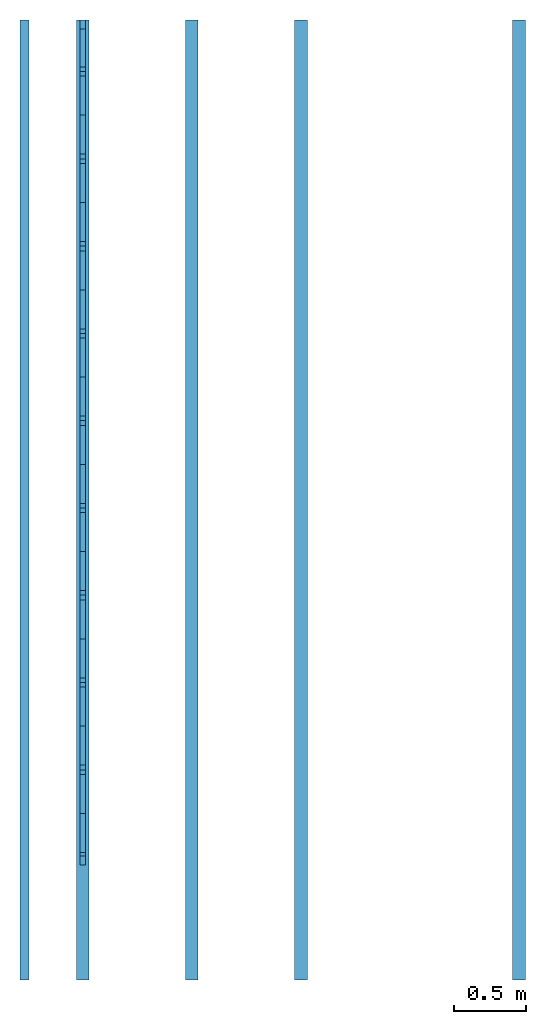
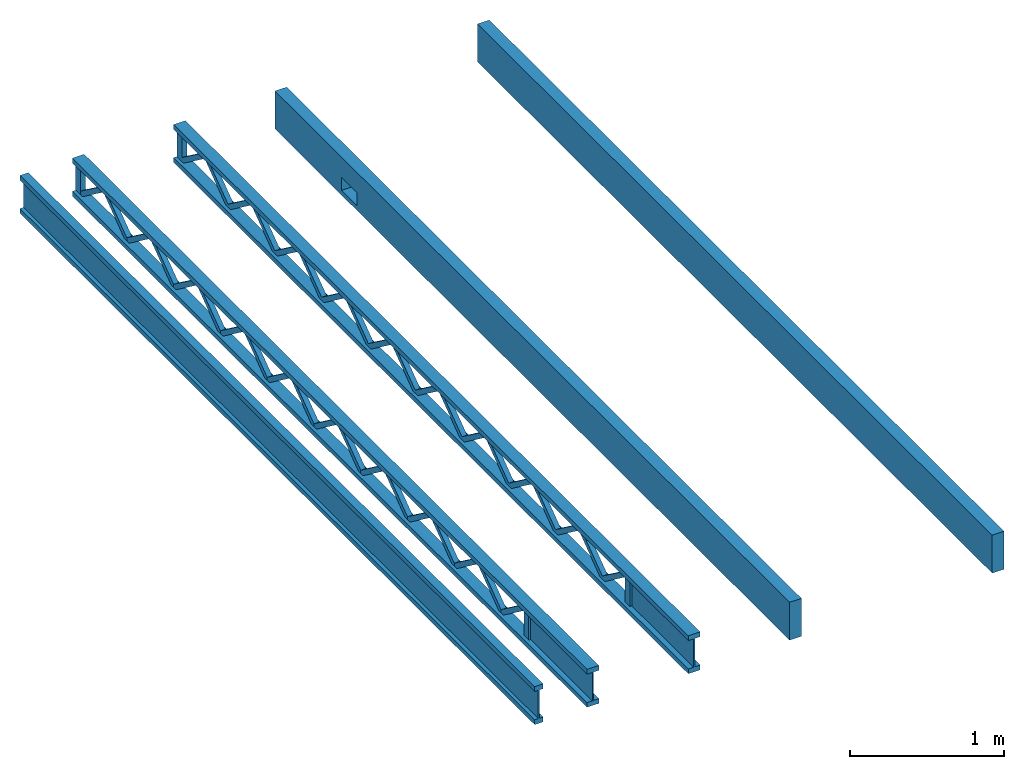
# One storey: 26 members.
"""IFC2X3 building model written with IfcOpenShell, lengths in metres."""

from ifc_helpers import new_model, si_unit, direction, frame, origin_with_axes, place, context, subcontext, project, spatial, faceted_brep, material, element, save


model = new_model("IFC2X3")

# Units and contexts
model_context = context("Model", 3, precision=1e-06, world=origin_with_axes(), true_north=direction((0.0, 1.0)))
body_context = subcontext(model_context, "Body", "Model", "MODEL_VIEW")
ifc_project = project(units=[si_unit("LENGTHUNIT", "METRE"), si_unit("AREAUNIT", "SQUARE_METRE"), si_unit("VOLUMEUNIT", "CUBIC_METRE"), si_unit("PLANEANGLEUNIT", "RADIAN"), si_unit("MASSUNIT", "GRAM", prefix="KILO")], contexts=[model_context])

# Site, building, storey
site_placement = place(None, origin_with_axes())
site = spatial("IfcSite", under=ifc_project, at=site_placement, CompositionType="ELEMENT")
building_placement = place(site_placement, origin_with_axes())
building = spatial("IfcBuilding", under=site, at=building_placement, Name="Building 1", CompositionType="ELEMENT")
storey_placement = place(building_placement, origin_with_axes())
storey = spatial("IfcBuildingStorey", under=building, at=storey_placement, Name="Storey 1", CompositionType="ELEMENT", Elevation=0.0)

# Members
ifc_material_1 = material(Name="Glass")
member_1_placement = place(storey_placement, frame((58.88355, 9.0424, -39.8871125), z_axis=(0.0, 0.0, 1.0), x_axis=(0.0, -1.0, 0.0)))
element("IfcMember", 1, at=member_1_placement, inside=storey, material=ifc_material_1, Name="Rough Volume Truss", context=body_context, shape_type="Brep", body=[
    faceted_brep([(0.0, -0.04445, -0.1508125), (0.0, 0.04445, -0.1508125), (6.7056, 0.04445, -0.1508125), (6.7056, -0.04445, -0.1508125), (0.0, 0.04445, 0.1508125), (6.7056, 0.04445, 0.1508125), (0.0, -0.04445, 0.1508125), (6.7056, -0.04445, 0.1508125)], [[[0, 1, 2, 3]], [[2, 1, 4, 5]], [[1, 0, 6, 4]], [[3, 2, 5, 7]], [[0, 3, 7, 6]], [[5, 4, 6, 7]]]),
])
ifc_material_2 = material(Name="fir")
member_2_placement = place(storey_placement, frame((55.42915, 9.0424, -39.8871125), z_axis=(0.0, 0.0, 1.0), x_axis=(0.0, -1.0, 0.0)))
element("IfcMember", 2, at=member_2_placement, inside=storey, material=ifc_material_2, Name="I Joist", context=body_context, shape_type="Brep", body=[
    faceted_brep([(0.0, 0.0047625, -0.1127125), (0.0, 0.0047625, 0.1127125), (6.7056, 0.0047625, 0.1127125), (6.7056, 0.0047625, -0.1127125), (0.0, 0.03175, 0.1127125), (6.7056, 0.03175, 0.1127125), (0.0, 0.03175, 0.1508125), (6.7056, 0.03175, 0.1508125), (0.0, -0.03175, 0.1508125), (6.7056, -0.03175, 0.1508125), (0.0, -0.03175, 0.1127125), (6.7056, -0.03175, 0.1127125), (0.0, -0.0047625, 0.1127125), (6.7056, -0.0047625, 0.1127125), (0.0, -0.0047625, -0.1127125), (6.7056, -0.0047625, -0.1127125), (0.0, -0.03175, -0.1127125), (6.7056, -0.03175, -0.1127125), (0.0, -0.03175, -0.1508125), (6.7056, -0.03175, -0.1508125), (0.0, 0.03175, -0.1508125), (6.7056, 0.03175, -0.1508125), (0.0, 0.03175, -0.1127125), (6.7056, 0.03175, -0.1127125)], [[[0, 1, 2, 3]], [[1, 4, 5, 2]], [[5, 4, 6, 7]], [[7, 6, 8, 9]], [[10, 11, 9, 8]], [[10, 12, 13, 11]], [[12, 14, 15, 13]], [[14, 16, 17, 15]], [[17, 16, 18, 19]], [[19, 18, 20, 21]], [[22, 23, 21, 20]], [[22, 0, 3, 23]], [[0, 22, 20, 18, 16, 14, 12, 10, 8, 6, 4, 1]], [[23, 3, 2, 5, 7, 9, 11, 13, 15, 17, 19, 21]]]),
])
member_3_placement = place(storey_placement, frame((55.83555, 5.6342122, -39.7741643), z_axis=(0.0, -0.595333, -0.8034791), x_axis=(0.0, 0.8034791, -0.595333)))
element("IfcMember", 3, at=member_3_placement, inside=storey, material=ifc_material_2, context=body_context, shape_type="Brep", body=[
    faceted_brep([(0.3791034, -0.01905, -3.98e-05), (0.3791034, 0.01905, -3.98e-05), (0.3533391, 0.01905, 0.01905), (0.3533391, -0.01905, 0.01905), (0.0138976, -0.01905, 0.01905), (0.0, -0.01905, 0.0002934), (0.0261064, -0.01905, -0.01905), (0.3650179, -0.01905, -0.01905), (0.3650179, 0.01905, -0.01905), (0.0261064, 0.01905, -0.01905), (0.0, 0.01905, 0.0002934), (0.0138976, 0.01905, 0.01905)], [[[0, 1, 2, 3]], [[0, 3, 4, 5, 6, 7]], [[1, 0, 7, 8]], [[8, 7, 6, 9]], [[2, 1, 8, 9, 10, 11]], [[5, 10, 9, 6]], [[10, 5, 4, 11]], [[3, 2, 11, 4]]]),
])
member_4_placement = place(storey_placement, frame((55.83555, 5.6338628, -39.7741643), z_axis=(0.0, 0.595333, -0.8034791), x_axis=(0.0, -0.8034791, -0.595333)))
element("IfcMember", 4, at=member_4_placement, inside=storey, material=ifc_material_2, context=body_context, shape_type="Brep", body=[
    faceted_brep([(0.3791034, -0.01905, -3.98e-05), (0.3791034, 0.01905, -3.98e-05), (0.3533391, 0.01905, 0.01905), (0.3533391, -0.01905, 0.01905), (0.3650179, 0.01905, -0.01905), (0.0261064, 0.01905, -0.01905), (0.0, 0.01905, 0.0002934), (0.0138976, 0.01905, 0.01905), (0.3650179, -0.01905, -0.01905), (0.0261064, -0.01905, -0.01905), (0.0138976, -0.01905, 0.01905), (0.0, -0.01905, 0.0002934)], [[[0, 1, 2, 3]], [[2, 1, 4, 5, 6, 7]], [[1, 0, 8, 4]], [[4, 8, 9, 5]], [[0, 3, 10, 11, 9, 8]], [[11, 6, 5, 9]], [[6, 11, 10, 7]], [[3, 2, 7, 10]]]),
])
member_5_placement = place(storey_placement, frame((55.83555, 8.6822122, -39.7741643), z_axis=(0.0, -0.595333, -0.8034791), x_axis=(0.0, 0.8034791, -0.595333)))
element("IfcMember", 5, at=member_5_placement, inside=storey, material=ifc_material_2, context=body_context, shape_type="Brep", body=[
    faceted_brep([(0.3791034, -0.01905, -3.98e-05), (0.3791034, 0.01905, -3.98e-05), (0.3533391, 0.01905, 0.01905), (0.3533391, -0.01905, 0.01905), (0.0138976, -0.01905, 0.01905), (0.0, -0.01905, 0.0002934), (0.0261064, -0.01905, -0.01905), (0.3650179, -0.01905, -0.01905), (0.3650179, 0.01905, -0.01905), (0.0261064, 0.01905, -0.01905), (0.0, 0.01905, 0.0002934), (0.0138976, 0.01905, 0.01905)], [[[0, 1, 2, 3]], [[0, 3, 4, 5, 6, 7]], [[1, 0, 7, 8]], [[8, 7, 6, 9]], [[2, 1, 8, 9, 10, 11]], [[5, 10, 9, 6]], [[10, 5, 4, 11]], [[3, 2, 11, 4]]]),
])
member_6_placement = place(storey_placement, frame((55.83555, 9.01065, -39.7744), z_axis=(0.0, -1.0, 0.0), x_axis=(0.0, 0.0, -1.0)))
element("IfcMember", 6, at=member_6_placement, inside=storey, material=ifc_material_2, context=body_context, shape_type="Brep", body=[
    faceted_brep([(0.225425, 0.01905, -0.03175), (0.225425, 0.01905, 0.03175), (0.225425, -0.01905, 0.03175), (0.225425, -0.01905, -0.03175), (0.0, 0.01905, 0.03175), (0.0, 0.01905, -0.03175), (0.0, -0.01905, -0.03175), (0.0, -0.01905, 0.03175)], [[[0, 1, 2, 3]], [[4, 5, 6, 7]], [[3, 6, 5, 0]], [[2, 7, 6, 3]], [[1, 4, 7, 2]], [[0, 5, 4, 1]]]),
])
member_7_placement = place(storey_placement, frame((55.83555, 3.8050628, -39.7741643), z_axis=(0.0, 0.595333, -0.8034791), x_axis=(0.0, -0.8034791, -0.595333)))
element("IfcMember", 7, at=member_7_placement, inside=storey, material=ifc_material_2, context=body_context, shape_type="Brep", body=[
    faceted_brep([(0.3791034, -0.01905, -3.98e-05), (0.3791034, 0.01905, -3.98e-05), (0.3533391, 0.01905, 0.01905), (0.3533391, -0.01905, 0.01905), (0.3650179, 0.01905, -0.01905), (0.0261064, 0.01905, -0.01905), (0.0, 0.01905, 0.0002934), (0.0138976, 0.01905, 0.01905), (0.3650179, -0.01905, -0.01905), (0.0261064, -0.01905, -0.01905), (0.0138976, -0.01905, 0.01905), (0.0, -0.01905, 0.0002934)], [[[0, 1, 2, 3]], [[2, 1, 4, 5, 6, 7]], [[1, 0, 8, 4]], [[4, 8, 9, 5]], [[0, 3, 10, 11, 9, 8]], [[11, 6, 5, 9]], [[6, 11, 10, 7]], [[3, 2, 7, 10]]]),
])
for number, where, z_axis, x_axis in (
    (8, (55.83555, 4.4150122, -39.7741643), (0.0, -0.595333, -0.8034791), (0.0, 0.8034791, -0.595333)),
    (9, (55.83555, 8.0726122, -39.7741643), (0.0, -0.595333, -0.8034791), (0.0, 0.8034791, -0.595333)),
    (10, (55.83555, 3.8054122, -39.7741643), (0.0, -0.595333, -0.8034791), (0.0, 0.8034791, -0.595333)),
):
    element("IfcMember", number, at=place(storey_placement, frame(where, z_axis=z_axis, x_axis=x_axis)), inside=storey, material=ifc_material_2, context=body_context, shape_type="Brep", body=[
        faceted_brep([(0.3791034, -0.01905, -3.98e-05), (0.3791034, 0.01905, -3.98e-05), (0.3533391, 0.01905, 0.01905), (0.3533391, -0.01905, 0.01905), (0.0138976, -0.01905, 0.01905), (0.0, -0.01905, 0.0002934), (0.0261064, -0.01905, -0.01905), (0.3650179, -0.01905, -0.01905), (0.3650179, 0.01905, -0.01905), (0.0261064, 0.01905, -0.01905), (0.0, 0.01905, 0.0002934), (0.0138976, 0.01905, 0.01905)], [[[0, 1, 2, 3]], [[0, 3, 4, 5, 6, 7]], [[1, 0, 7, 8]], [[8, 7, 6, 9]], [[2, 1, 8, 9, 10, 11]], [[5, 10, 9, 6]], [[10, 5, 4, 11]], [[3, 2, 11, 4]]]),
    ])
member_8_placement = place(storey_placement, frame((55.83555, 9.0424, -39.8871125), z_axis=(0.0, 0.0, 1.0), x_axis=(0.0, -1.0, 0.0)))
element("IfcMember", 11, at=member_8_placement, inside=storey, material=ifc_material_2, context=body_context, shape_type="Brep", body=[
    faceted_brep([(6.7056, 0.04445, 0.1508125), (0.0, 0.04445, 0.1508125), (0.0, -0.04445, 0.1508125), (6.7056, -0.04445, 0.1508125), (0.0, 0.04445, 0.1127125), (0.0, -0.04445, 0.1127125), (6.7056, 0.0047625, 0.1127125), (5.902325, 0.0047625, 0.1127125), (5.902325, -0.0047625, 0.1127125), (6.7056, -0.0047625, 0.1127125), (6.7056, -0.04445, 0.1127125), (6.7056, 0.04445, 0.1127125), (0.0, -0.04445, -0.1127125), (0.0, 0.04445, -0.1127125), (0.0, 0.04445, -0.1508125), (0.0, -0.04445, -0.1508125), (6.7056, -0.04445, -0.1508125), (6.7056, 0.04445, -0.1508125), (6.7056, 0.04445, -0.1127125), (6.7056, 0.0047625, -0.1127125), (6.7056, -0.0047625, -0.1127125), (6.7056, -0.04445, -0.1127125), (5.902325, -0.0047625, -0.1127125), (5.902325, 0.0047625, -0.1127125)], [[[0, 1, 2, 3]], [[4, 5, 2, 1]], [[6, 7, 8, 9, 10, 5, 4, 11]], [[12, 13, 14, 15]], [[16, 15, 14, 17]], [[11, 4, 1, 0]], [[18, 19, 6, 11, 0, 3, 10, 9, 20, 21, 16, 17]], [[18, 13, 12, 21, 20, 22, 23, 19]], [[13, 18, 17, 14]], [[5, 10, 3, 2]], [[8, 22, 20, 9]], [[23, 7, 6, 19]], [[7, 23, 22, 8]], [[21, 12, 15, 16]]]),
])
for number, where, z_axis, x_axis in (
    (12, (55.83555, 5.0242628, -39.7741643), (0.0, 0.595333, -0.8034791), (0.0, -0.8034791, -0.595333)),
    (13, (55.83555, 8.6818628, -39.7741643), (0.0, 0.595333, -0.8034791), (0.0, -0.8034791, -0.595333)),
    (14, (55.83555, 6.2434628, -39.7741643), (0.0, 0.595333, -0.8034791), (0.0, -0.8034791, -0.595333)),
):
    element("IfcMember", number, at=place(storey_placement, frame(where, z_axis=z_axis, x_axis=x_axis)), inside=storey, material=ifc_material_2, context=body_context, shape_type="Brep", body=[
        faceted_brep([(0.3791034, -0.01905, -3.98e-05), (0.3791034, 0.01905, -3.98e-05), (0.3533391, 0.01905, 0.01905), (0.3533391, -0.01905, 0.01905), (0.3650179, 0.01905, -0.01905), (0.0261064, 0.01905, -0.01905), (0.0, 0.01905, 0.0002934), (0.0138976, 0.01905, 0.01905), (0.3650179, -0.01905, -0.01905), (0.0261064, -0.01905, -0.01905), (0.0138976, -0.01905, 0.01905), (0.0, -0.01905, 0.0002934)], [[[0, 1, 2, 3]], [[2, 1, 4, 5, 6, 7]], [[1, 0, 8, 4]], [[4, 8, 9, 5]], [[0, 3, 10, 11, 9, 8]], [[11, 6, 5, 9]], [[6, 11, 10, 7]], [[3, 2, 7, 10]]]),
    ])
member_9_placement = place(storey_placement, frame((55.83555, 5.0246122, -39.7741643), z_axis=(0.0, -0.595333, -0.8034791), x_axis=(0.0, 0.8034791, -0.595333)))
element("IfcMember", 15, at=member_9_placement, inside=storey, material=ifc_material_2, context=body_context, shape_type="Brep", body=[
    faceted_brep([(0.3791034, -0.01905, -3.98e-05), (0.3791034, 0.01905, -3.98e-05), (0.3533391, 0.01905, 0.01905), (0.3533391, -0.01905, 0.01905), (0.0138976, -0.01905, 0.01905), (0.0, -0.01905, 0.0002934), (0.0261064, -0.01905, -0.01905), (0.3650179, -0.01905, -0.01905), (0.3650179, 0.01905, -0.01905), (0.0261064, 0.01905, -0.01905), (0.0, 0.01905, 0.0002934), (0.0138976, 0.01905, 0.01905)], [[[0, 1, 2, 3]], [[0, 3, 4, 5, 6, 7]], [[1, 0, 7, 8]], [[8, 7, 6, 9]], [[2, 1, 8, 9, 10, 11]], [[5, 10, 9, 6]], [[10, 5, 4, 11]], [[3, 2, 11, 4]]]),
])
member_10_placement = place(storey_placement, frame((55.83555, 3.171825, -39.7744), z_axis=(0.0, -1.0, 0.0), x_axis=(0.0, 0.0, -1.0)))
element("IfcMember", 16, at=member_10_placement, inside=storey, material=ifc_material_2, context=body_context, shape_type="Brep", body=[
    faceted_brep([(0.225425, 0.01905, -0.03175), (0.225425, 0.01905, 0.03175), (0.225425, -0.01905, 0.03175), (0.225425, -0.01905, -0.03175), (0.0, 0.01905, 0.03175), (0.0, 0.01905, -0.03175), (0.0, -0.01905, -0.03175), (0.0, -0.01905, 0.03175)], [[[0, 1, 2, 3]], [[4, 5, 6, 7]], [[3, 6, 5, 0]], [[2, 7, 6, 3]], [[1, 4, 7, 2]], [[0, 5, 4, 1]]]),
])
member_11_placement = place(storey_placement, frame((55.83555, 6.2438122, -39.7741643), z_axis=(0.0, -0.595333, -0.8034791), x_axis=(0.0, 0.8034791, -0.595333)))
element("IfcMember", 17, at=member_11_placement, inside=storey, material=ifc_material_2, context=body_context, shape_type="Brep", body=[
    faceted_brep([(0.3791034, -0.01905, -3.98e-05), (0.3791034, 0.01905, -3.98e-05), (0.3533391, 0.01905, 0.01905), (0.3533391, -0.01905, 0.01905), (0.0138976, -0.01905, 0.01905), (0.0, -0.01905, 0.0002934), (0.0261064, -0.01905, -0.01905), (0.3650179, -0.01905, -0.01905), (0.3650179, 0.01905, -0.01905), (0.0261064, 0.01905, -0.01905), (0.0, 0.01905, 0.0002934), (0.0138976, 0.01905, 0.01905)], [[[0, 1, 2, 3]], [[0, 3, 4, 5, 6, 7]], [[1, 0, 7, 8]], [[8, 7, 6, 9]], [[2, 1, 8, 9, 10, 11]], [[5, 10, 9, 6]], [[10, 5, 4, 11]], [[3, 2, 11, 4]]]),
])
member_12_placement = place(storey_placement, frame((55.83555, 7.4626628, -39.7741643), z_axis=(0.0, 0.595333, -0.8034791), x_axis=(0.0, -0.8034791, -0.595333)))
element("IfcMember", 18, at=member_12_placement, inside=storey, material=ifc_material_2, context=body_context, shape_type="Brep", body=[
    faceted_brep([(0.3791034, -0.01905, -3.98e-05), (0.3791034, 0.01905, -3.98e-05), (0.3533391, 0.01905, 0.01905), (0.3533391, -0.01905, 0.01905), (0.3650179, 0.01905, -0.01905), (0.0261064, 0.01905, -0.01905), (0.0, 0.01905, 0.0002934), (0.0138976, 0.01905, 0.01905), (0.3650179, -0.01905, -0.01905), (0.0261064, -0.01905, -0.01905), (0.0138976, -0.01905, 0.01905), (0.0, -0.01905, 0.0002934)], [[[0, 1, 2, 3]], [[2, 1, 4, 5, 6, 7]], [[1, 0, 8, 4]], [[4, 8, 9, 5]], [[0, 3, 10, 11, 9, 8]], [[11, 6, 5, 9]], [[6, 11, 10, 7]], [[3, 2, 7, 10]]]),
])
member_13_placement = place(storey_placement, frame((56.59755, 9.0424, -39.8871125), z_axis=(0.0, 0.0, 1.0), x_axis=(0.0, -1.0, 0.0)))
element("IfcMember", 19, at=member_13_placement, inside=storey, material=ifc_material_2, context=body_context, shape_type="Brep", body=[
    faceted_brep([(5.902325, 0.0047625, 0.1127125), (5.902325, 0.0047625, -0.1127125), (5.902325, 0.01905, -0.1127125), (5.902325, 0.01905, 0.1127125), (5.902325, -0.0047625, -0.1127125), (5.902325, -0.0047625, 0.1127125), (5.902325, -0.01905, 0.1127125), (5.902325, -0.01905, -0.1127125), (3.1035625, 0.01905, -0.0890527), (3.1035625, -0.01905, -0.0890527), (3.3758708, -0.01905, 0.1127125), (3.3758708, 0.01905, 0.1127125), (3.1356283, -0.01905, -0.1127125), (3.1356283, 0.01905, -0.1127125), (3.4083625, 0.01905, 0.0893682), (3.4083625, -0.01905, 0.0893682), (3.7131625, -0.01905, -0.0890527), (3.7131625, 0.01905, -0.0890527), (3.4408542, 0.01905, 0.1127125), (3.4408542, -0.01905, 0.1127125), (3.6810967, 0.01905, -0.1127125), (3.6810967, -0.01905, -0.1127125), (3.9854708, -0.01905, 0.1127125), (3.9854708, 0.01905, 0.1127125), (3.7452283, -0.01905, -0.1127125), (3.7452283, 0.01905, -0.1127125), (4.0179625, 0.01905, 0.0893682), (4.0179625, -0.01905, 0.0893682), (4.3227625, -0.01905, -0.0890527), (4.3227625, 0.01905, -0.0890527), (4.0504542, 0.01905, 0.1127125), (4.0504542, -0.01905, 0.1127125), (4.2906967, 0.01905, -0.1127125), (4.2906967, -0.01905, -0.1127125), (4.5950708, -0.01905, 0.1127125), (4.5950708, 0.01905, 0.1127125), (4.3548283, -0.01905, -0.1127125), (4.3548283, 0.01905, -0.1127125), (4.6275625, 0.01905, 0.0893682), (4.6275625, -0.01905, 0.0893682), (4.9323625, -0.01905, -0.0890527), (4.9323625, 0.01905, -0.0890527), (4.6600542, 0.01905, 0.1127125), (4.6600542, -0.01905, 0.1127125), (4.9002967, 0.01905, -0.1127125), (4.9002967, -0.01905, -0.1127125), (5.2046708, -0.01905, 0.1127125), (5.2046708, 0.01905, 0.1127125), (4.9644283, -0.01905, -0.1127125), (4.9644283, 0.01905, -0.1127125), (5.2371625, 0.01905, 0.0893682), (5.2371625, -0.01905, 0.0893682), (5.5419625, -0.01905, -0.0890527), (5.5419625, 0.01905, -0.0890527), (5.2696542, 0.01905, 0.1127125), (5.2696542, -0.01905, 0.1127125), (5.5098967, 0.01905, -0.1127125), (5.5098967, -0.01905, -0.1127125), (5.838825, -0.01905, 0.083487), (5.838825, 0.01905, 0.083487), (5.838825, 0.01905, -0.1127125), (5.838825, -0.01905, -0.1127125), (5.8142708, -0.01905, 0.1127125), (5.8142708, 0.01905, 0.1127125), (5.5740283, -0.01905, -0.1127125), (5.5740283, 0.01905, -0.1127125), (2.8312542, 0.01905, 0.1127125), (2.8312542, -0.01905, 0.1127125), (3.0714967, 0.01905, -0.1127125), (3.0714967, -0.01905, -0.1127125), (2.7987625, -0.01905, 0.0893682), (2.7987625, 0.01905, 0.0893682), (2.4939625, 0.01905, -0.0890527), (2.4939625, -0.01905, -0.0890527), (2.7662708, -0.01905, 0.1127125), (2.7662708, 0.01905, 0.1127125), (2.5260283, -0.01905, -0.1127125), (2.5260283, 0.01905, -0.1127125), (2.2216542, 0.01905, 0.1127125), (2.2216542, -0.01905, 0.1127125), (2.4618967, 0.01905, -0.1127125), (2.4618967, -0.01905, -0.1127125), (2.1891625, -0.01905, 0.0893682), (2.1891625, 0.01905, 0.0893682), (1.8843625, 0.01905, -0.0890527), (1.8843625, -0.01905, -0.0890527), (2.1566708, -0.01905, 0.1127125), (2.1566708, 0.01905, 0.1127125), (1.9164283, -0.01905, -0.1127125), (1.9164283, 0.01905, -0.1127125), (1.6120542, 0.01905, 0.1127125), (1.6120542, -0.01905, 0.1127125), (1.8522967, 0.01905, -0.1127125), (1.8522967, -0.01905, -0.1127125), (1.5795625, -0.01905, 0.0893682), (1.5795625, 0.01905, 0.0893682), (1.2747625, 0.01905, -0.0890527), (1.2747625, -0.01905, -0.0890527), (1.5470708, -0.01905, 0.1127125), (1.5470708, 0.01905, 0.1127125), (1.3068283, -0.01905, -0.1127125), (1.3068283, 0.01905, -0.1127125), (1.0024542, 0.01905, 0.1127125), (1.0024542, -0.01905, 0.1127125), (1.2426967, 0.01905, -0.1127125), (1.2426967, -0.01905, -0.1127125), (0.9699625, -0.01905, 0.0893682), (0.9699625, 0.01905, 0.0893682), (0.6651625, 0.01905, -0.0890527), (0.6651625, -0.01905, -0.0890527), (0.9374708, -0.01905, 0.1127125), (0.9374708, 0.01905, 0.1127125), (0.6972283, -0.01905, -0.1127125), (0.6972283, 0.01905, -0.1127125), (0.3928542, 0.01905, 0.1127125), (0.3928542, -0.01905, 0.1127125), (0.6330967, 0.01905, -0.1127125), (0.6330967, -0.01905, -0.1127125), (0.3603625, -0.01905, 0.0893682), (0.3603625, 0.01905, 0.0893682), (0.0635, -0.01905, -0.0831715), (0.0635, 0.01905, -0.0831715), (0.0635, 0.01905, 0.1127125), (0.0635, -0.01905, 0.1127125), (0.3278708, -0.01905, 0.1127125), (0.3278708, 0.01905, 0.1127125), (0.0, -0.01905, 0.1127125), (0.0, -0.01905, -0.1127125), (0.0876283, -0.01905, -0.1127125), (0.0876283, 0.01905, -0.1127125), (0.0, 0.01905, -0.1127125), (0.0, 0.01905, 0.1127125), (6.7056, 0.0047625, -0.1127125), (6.7056, 0.04445, -0.1127125), (0.0, 0.04445, -0.1127125), (0.0, -0.04445, -0.1127125), (6.7056, -0.04445, -0.1127125), (6.7056, -0.0047625, -0.1127125), (6.7056, -0.0047625, 0.1127125), (6.7056, -0.04445, 0.1127125), (0.0, -0.04445, 0.1127125), (0.0, 0.04445, 0.1127125), (6.7056, 0.04445, 0.1127125), (6.7056, 0.0047625, 0.1127125), (6.7056, 0.04445, 0.1508125), (0.0, 0.04445, 0.1508125), (0.0, -0.04445, 0.1508125), (6.7056, -0.04445, 0.1508125), (0.0, 0.04445, -0.1508125), (0.0, -0.04445, -0.1508125), (6.7056, -0.04445, -0.1508125), (6.7056, 0.04445, -0.1508125)], [[[0, 1, 2, 3]], [[4, 5, 6, 7]], [[8, 9, 10, 11]], [[12, 13, 14, 15]], [[16, 17, 18, 19]], [[20, 21, 15, 14]], [[17, 16, 22, 23]], [[24, 25, 26, 27]], [[28, 29, 30, 31]], [[32, 33, 27, 26]], [[29, 28, 34, 35]], [[36, 37, 38, 39]], [[40, 41, 42, 43]], [[44, 45, 39, 38]], [[41, 40, 46, 47]], [[48, 49, 50, 51]], [[52, 53, 54, 55]], [[56, 57, 51, 50]], [[58, 59, 60, 61]], [[53, 52, 62, 63]], [[59, 58, 64, 65]], [[9, 8, 66, 67]], [[68, 69, 70, 71]], [[72, 73, 74, 75]], [[76, 77, 71, 70]], [[73, 72, 78, 79]], [[80, 81, 82, 83]], [[84, 85, 86, 87]], [[88, 89, 83, 82]], [[85, 84, 90, 91]], [[92, 93, 94, 95]], [[96, 97, 98, 99]], [[100, 101, 95, 94]], [[97, 96, 102, 103]], [[104, 105, 106, 107]], [[108, 109, 110, 111]], [[112, 113, 107, 106]], [[109, 108, 114, 115]], [[116, 117, 118, 119]], [[120, 121, 122, 123]], [[121, 120, 124, 125]], [[124, 120, 123, 126, 127, 128, 118, 117, 112, 106, 105, 100, 94, 93, 88, 82, 81, 76, 70, 69, 12, 15, 21, 24, 27, 33, 36, 39, 45, 48, 51, 57, 64, 58, 61, 7, 6, 62, 52, 55, 46, 40, 43, 34, 28, 31, 22, 16, 19, 10, 9, 67, 74, 73, 79, 86, 85, 91, 98, 97, 103, 110, 109, 115]], [[129, 130, 131, 122, 121, 125, 114, 108, 111, 102, 96, 99, 90, 84, 87, 78, 72, 75, 66, 8, 11, 18, 17, 23, 30, 29, 35, 42, 41, 47, 54, 53, 63, 3, 2, 60, 59, 65, 56, 50, 49, 44, 38, 37, 32, 26, 25, 20, 14, 13, 68, 71, 77, 80, 83, 89, 92, 95, 101, 104, 107, 113, 116, 119]], [[128, 129, 119, 118]], [[4, 7, 61, 60, 2, 1, 132, 133, 134, 130, 129, 128, 127, 135, 136, 137], [25, 24, 21, 20], [37, 36, 33, 32], [49, 48, 45, 44], [65, 64, 57, 56], [69, 68, 13, 12], [81, 80, 77, 76], [93, 92, 89, 88], [105, 104, 101, 100], [117, 116, 113, 112]], [[6, 5, 138, 139, 140, 126, 123, 122, 131, 141, 142, 143, 0, 3, 63, 62], [125, 124, 115, 114], [111, 110, 103, 102], [99, 98, 91, 90], [87, 86, 79, 78], [75, 74, 67, 66], [55, 54, 47, 46], [43, 42, 35, 34], [31, 30, 23, 22], [19, 18, 11, 10]], [[144, 145, 146, 147]], [[135, 127, 126, 140, 146, 145, 141, 131, 130, 134, 148, 149]], [[150, 149, 148, 151]], [[142, 141, 145, 144]], [[133, 132, 143, 142, 144, 147, 139, 138, 137, 136, 150, 151]], [[134, 133, 151, 148]], [[140, 139, 147, 146]], [[5, 4, 137, 138]], [[1, 0, 143, 132]], [[136, 135, 149, 150]]]),
])
member_14_placement = place(storey_placement, frame((55.83555, 3.1958122, -39.7741643), z_axis=(0.0, -0.595333, -0.8034791), x_axis=(0.0, 0.8034791, -0.595333)))
element("IfcMember", 20, at=member_14_placement, inside=storey, material=ifc_material_2, context=body_context, shape_type="Brep", body=[
    faceted_brep([(0.3791034, -0.01905, -3.98e-05), (0.3791034, 0.01905, -3.98e-05), (0.3533391, 0.01905, 0.01905), (0.3533391, -0.01905, 0.01905), (0.0138976, -0.01905, 0.01905), (0.0, -0.01905, 0.0002934), (0.0261064, -0.01905, -0.01905), (0.3650179, -0.01905, -0.01905), (0.3650179, 0.01905, -0.01905), (0.0261064, 0.01905, -0.01905), (0.0, 0.01905, 0.0002934), (0.0138976, 0.01905, 0.01905)], [[[0, 1, 2, 3]], [[0, 3, 4, 5, 6, 7]], [[1, 0, 7, 8]], [[8, 7, 6, 9]], [[2, 1, 8, 9, 10, 11]], [[5, 10, 9, 6]], [[10, 5, 4, 11]], [[3, 2, 11, 4]]]),
])
member_15_placement = place(storey_placement, frame((55.83555, 4.4146628, -39.7741643), z_axis=(0.0, 0.595333, -0.8034791), x_axis=(0.0, -0.8034791, -0.595333)))
element("IfcMember", 21, at=member_15_placement, inside=storey, material=ifc_material_2, context=body_context, shape_type="Brep", body=[
    faceted_brep([(0.3791034, -0.01905, -3.98e-05), (0.3791034, 0.01905, -3.98e-05), (0.3533391, 0.01905, 0.01905), (0.3533391, -0.01905, 0.01905), (0.3650179, 0.01905, -0.01905), (0.0261064, 0.01905, -0.01905), (0.0, 0.01905, 0.0002934), (0.0138976, 0.01905, 0.01905), (0.3650179, -0.01905, -0.01905), (0.0261064, -0.01905, -0.01905), (0.0138976, -0.01905, 0.01905), (0.0, -0.01905, 0.0002934)], [[[0, 1, 2, 3]], [[2, 1, 4, 5, 6, 7]], [[1, 0, 8, 4]], [[4, 8, 9, 5]], [[0, 3, 10, 11, 9, 8]], [[11, 6, 5, 9]], [[6, 11, 10, 7]], [[3, 2, 7, 10]]]),
])
for number, where, z_axis, x_axis in (
    (22, (55.83555, 7.4630122, -39.7741643), (0.0, -0.595333, -0.8034791), (0.0, 0.8034791, -0.595333)),
    (23, (55.83555, 6.8534122, -39.7741643), (0.0, -0.595333, -0.8034791), (0.0, 0.8034791, -0.595333)),
):
    element("IfcMember", number, at=place(storey_placement, frame(where, z_axis=z_axis, x_axis=x_axis)), inside=storey, material=ifc_material_2, context=body_context, shape_type="Brep", body=[
        faceted_brep([(0.3791034, -0.01905, -3.98e-05), (0.3791034, 0.01905, -3.98e-05), (0.3533391, 0.01905, 0.01905), (0.3533391, -0.01905, 0.01905), (0.0138976, -0.01905, 0.01905), (0.0, -0.01905, 0.0002934), (0.0261064, -0.01905, -0.01905), (0.3650179, -0.01905, -0.01905), (0.3650179, 0.01905, -0.01905), (0.0261064, 0.01905, -0.01905), (0.0, 0.01905, 0.0002934), (0.0138976, 0.01905, 0.01905)], [[[0, 1, 2, 3]], [[0, 3, 4, 5, 6, 7]], [[1, 0, 7, 8]], [[8, 7, 6, 9]], [[2, 1, 8, 9, 10, 11]], [[5, 10, 9, 6]], [[10, 5, 4, 11]], [[3, 2, 11, 4]]]),
    ])
for number, where, z_axis, x_axis in (
    (24, (55.83555, 8.0722628, -39.7741643), (0.0, 0.595333, -0.8034791), (0.0, -0.8034791, -0.595333)),
    (25, (55.83555, 6.8530628, -39.7741643), (0.0, 0.595333, -0.8034791), (0.0, -0.8034791, -0.595333)),
):
    element("IfcMember", number, at=place(storey_placement, frame(where, z_axis=z_axis, x_axis=x_axis)), inside=storey, material=ifc_material_2, context=body_context, shape_type="Brep", body=[
        faceted_brep([(0.3791034, -0.01905, -3.98e-05), (0.3791034, 0.01905, -3.98e-05), (0.3533391, 0.01905, 0.01905), (0.3533391, -0.01905, 0.01905), (0.3650179, 0.01905, -0.01905), (0.0261064, 0.01905, -0.01905), (0.0, 0.01905, 0.0002934), (0.0138976, 0.01905, 0.01905), (0.3650179, -0.01905, -0.01905), (0.0261064, -0.01905, -0.01905), (0.0138976, -0.01905, 0.01905), (0.0, -0.01905, 0.0002934)], [[[0, 1, 2, 3]], [[2, 1, 4, 5, 6, 7]], [[1, 0, 8, 4]], [[4, 8, 9, 5]], [[0, 3, 10, 11, 9, 8]], [[11, 6, 5, 9]], [[6, 11, 10, 7]], [[3, 2, 7, 10]]]),
    ])
member_16_placement = place(storey_placement, frame((57.35955, 9.0424, -39.8871125), z_axis=(0.0, 0.0, 1.0), x_axis=(0.0, -1.0, 0.0)))
element("IfcMember", 26, at=member_16_placement, inside=storey, material=ifc_material_1, Name="Rough Volume Truss", context=body_context, shape_type="Brep", body=[
    faceted_brep([(1.0715625, 0.04445, -0.0111125), (1.0715625, 0.04445, -0.1127125), (1.0715625, -0.04445, -0.1127125), (1.0715625, -0.04445, -0.0111125), (0.8683625, 0.04445, -0.0111125), (0.8683625, -0.04445, -0.0111125), (0.8683625, 0.04445, -0.1127125), (0.8683625, -0.04445, -0.1127125), (0.0, -0.04445, -0.1508125), (0.0, 0.04445, -0.1508125), (6.7056, 0.04445, -0.1508125), (6.7056, -0.04445, -0.1508125), (0.0, 0.04445, 0.1508125), (6.7056, 0.04445, 0.1508125), (0.0, -0.04445, 0.1508125), (6.7056, -0.04445, 0.1508125)], [[[0, 1, 2, 3]], [[4, 0, 3, 5]], [[6, 4, 5, 7]], [[1, 6, 7, 2]], [[8, 9, 10, 11]], [[10, 9, 12, 13], [4, 6, 1, 0]], [[9, 8, 14, 12]], [[11, 10, 13, 15]], [[8, 11, 15, 14], [7, 5, 3, 2]], [[13, 12, 14, 15]]]),
])

save(model, "model.ifc")
